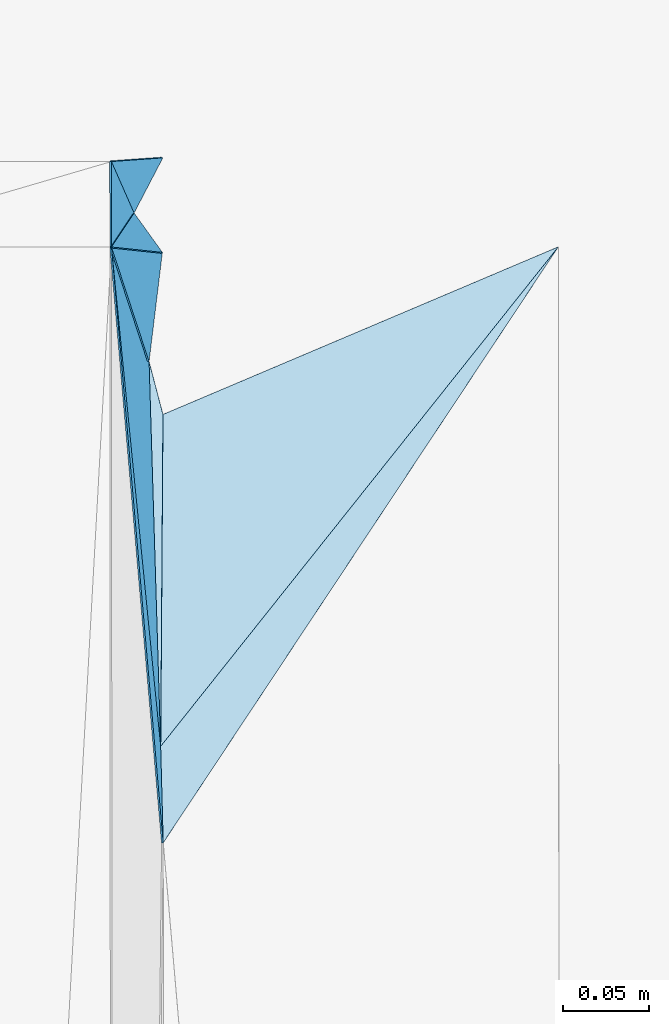
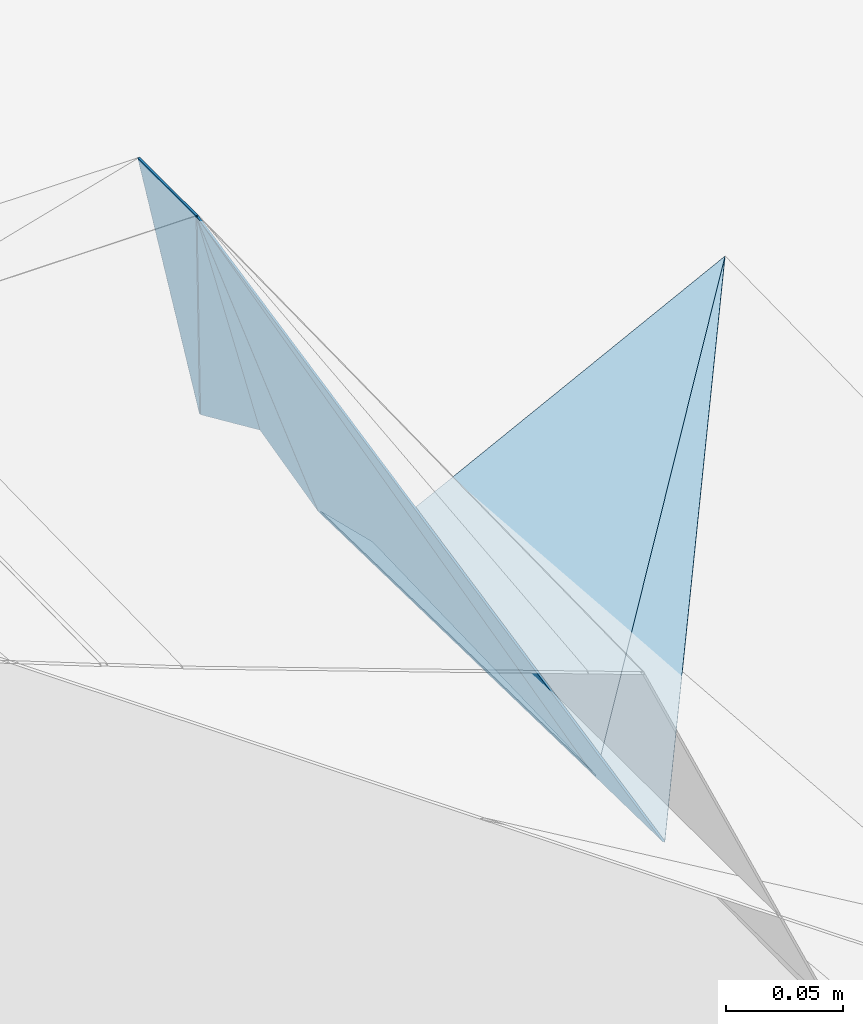
# One storey, part 177 of 275: 9 plates.
"""IFC2X3 building model written with IfcOpenShell, lengths in millimetres."""

from ifc_helpers import new_model, si_unit, frame, origin_with_axes, place, context, subcontext, project, spatial, polyline, outline, extrude, material, type_object, element, save


model = new_model("IFC2X3")

# Units and contexts
model_context = context("Model", 3, precision=1e-05, world=origin_with_axes())
body_context = subcontext(model_context, "Body", "Model", "MODEL_VIEW")
ifc_project = project(units=[si_unit("LENGTHUNIT", "METRE", prefix="MILLI"), si_unit("AREAUNIT", "SQUARE_METRE"), si_unit("VOLUMEUNIT", "CUBIC_METRE"), si_unit("MASSUNIT", "GRAM", prefix="KILO"), si_unit("TIMEUNIT", "SECOND"), si_unit("PLANEANGLEUNIT", "RADIAN"), si_unit("SOLIDANGLEUNIT", "STERADIAN"), si_unit("THERMODYNAMICTEMPERATUREUNIT", "DEGREE_CELSIUS"), si_unit("LUMINOUSINTENSITYUNIT", "LUMEN")], contexts=[model_context])

# Site, building, storey
site_placement = place(None, origin_with_axes())
site = spatial("IfcSite", under=ifc_project, at=site_placement, CompositionType="ELEMENT")
building_placement = place(site_placement, origin_with_axes())
building = spatial("IfcBuilding", under=site, at=building_placement, Name="Undefined", CompositionType="ELEMENT")
storey_placement = place(building_placement, origin_with_axes())
storey = spatial("IfcBuildingStorey", under=building, at=storey_placement, Name="Undefined", CompositionType="ELEMENT", Elevation=0.0)

# Plates
ifc_material = material()
plate_type_1 = type_object("IfcPlateType", PredefinedType="NOTDEFINED")
plate_1_placement = place(storey_placement, frame((-94142.7583722602, 80774.2076939146, 42554.9449686011), z_axis=(-0.867375950582127, 0.452072282208132, -0.208061558224681), x_axis=(-0.105980269993438, 0.240696950969147, 0.964796952817677)))
element("IfcPlate", 1, at=plate_1_placement, inside=storey, type_object=plate_type_1, material=ifc_material, Name="00_PR", context=body_context, shape_type="SweptSolid", body=[
    extrude(outline(polyline([(0.0, 0.0), (124.37850189209, 3.85625753551722e-10), (5.94483232498169, 35.6546897888184), (0.0, 0.0)])), frame((-8.85201319254618e-08, 2.18876761149539e-07, -0.5000001331573), z_axis=(0.0, 0.0, 1.0), x_axis=(1.0, 0.0, 0.0)), (0.0, 0.0, 1.0), 1.0),
])
plate_type_2 = type_object("IfcPlateType", PredefinedType="NOTDEFINED")
plate_2_placement = place(storey_placement, frame((-94155.9850719889, 80754.2292515049, 42674.9944492893), z_axis=(-0.994030688736773, -0.000365980365090597, -0.10910021039333), x_axis=(-0.00036817810698692, 0.999999932222439, -2.76748402294311e-11)))
element("IfcPlate", 2, at=plate_2_placement, inside=storey, type_object=plate_type_2, material=ifc_material, Name="00_PR", context=body_context, shape_type="SweptSolid", body=[
    extrude(outline(polyline([(0.0, 0.0), (49.689754486084, -1.96450855582953e-10), (19.7473754882813, 120.720611572266), (0.0, 0.0)])), frame((-8.85201319254618e-08, 2.18876761149539e-07, -0.5000001331573), z_axis=(0.0, 0.0, 1.0), x_axis=(1.0, 0.0, 0.0)), (0.0, 0.0, 1.0), 1.0),
])
plate_type_3 = type_object("IfcPlateType", PredefinedType="NOTDEFINED")
plate_3_placement = place(storey_placement, frame((-94134.0967544424, 80687.5979098779, 42553.4265810077), z_axis=(-0.962737602424916, 0.123019527590946, -0.240837091637531), x_axis=(-0.15587941593876, 0.475299576709344, 0.865905260445108)))
element("IfcPlate", 3, at=plate_3_placement, inside=storey, type_object=plate_type_3, material=ifc_material, Name="00_PR", context=body_context, shape_type="SweptSolid", body=[
    extrude(outline(polyline([(0.0, 0.0), (140.317886352539, -3.8198777474463e-10), (30.3008766174316, 56.421028137207), (0.0, 0.0)])), frame((-8.85201319254618e-08, 2.18876761149539e-07, -0.5000001331573), z_axis=(0.0, 0.0, 1.0), x_axis=(1.0, 0.0, 0.0)), (0.0, 0.0, 1.0), 1.0),
])
plate_type_4 = type_object("IfcPlateType", PredefinedType="NOTDEFINED")
plate_4_placement = place(storey_placement, frame((-94133.5973282973, 80687.5464707228, 42553.0474272175), z_axis=(0.0361171160985423, 0.0201399563112592, -0.999144602189545), x_axis=(0.253899373232063, -0.967175607462918, -0.0103175869805615)))
element("IfcPlate", 4, at=plate_4_placement, inside=storey, type_object=plate_type_4, material=ifc_material, Name="00_PR", context=body_context, shape_type="SweptSolid", body=[
    extrude(outline(polyline([(0.0, 0.0), (31.7903804779053, -7.27595761418343e-11), (218.229110717773, 50.3532638549805), (0.0, 0.0)])), frame((-8.85201319254618e-08, 2.18876761149539e-07, -0.5000001331573), z_axis=(0.0, 0.0, 1.0), x_axis=(1.0, 0.0, 0.0)), (0.0, 0.0, 1.0), 1.0),
])
plate_type_5 = type_object("IfcPlateType", PredefinedType="NOTDEFINED")
plate_5_placement = place(storey_placement, frame((-94127.3695423557, 80463.7022747809, 42549.1975225795), z_axis=(-0.986275361902605, -0.0265882475288504, -0.162953906357687), x_axis=(-0.0900133561065273, 0.913967783193759, 0.395677251059907)))
element("IfcPlate", 5, at=plate_5_placement, inside=storey, type_object=plate_type_5, material=ifc_material, Name="00_PR", context=body_context, shape_type="SweptSolid", body=[
    extrude(outline(polyline([(0.0, 0.0), (317.860076904297, 1.19689502753317e-09), (206.860382080078, 85.8380966186523), (0.0, 0.0)])), frame((-8.85201319254618e-08, 2.18876761149539e-07, -0.5000001331573), z_axis=(0.0, 0.0, 1.0), x_axis=(1.0, 0.0, 0.0)), (0.0, 0.0, 1.0), 1.0),
])
plate_type_6 = type_object("IfcPlateType", PredefinedType="NOTDEFINED")
plate_6_placement = place(storey_placement, frame((-93895.4723955215, 80754.3370529524, 42562.049356912), z_axis=(0.0319742993126876, 0.0201714169868267, -0.999285123535924), x_axis=(-0.622488952070591, -0.781813950260484, -0.0356994639757451)))
element("IfcPlate", 6, at=plate_6_placement, inside=storey, type_object=plate_type_6, material=ifc_material, Name="00_PR", context=body_context, shape_type="SweptSolid", body=[
    extrude(outline(polyline([(0.0, 0.0), (371.714263916016, -2.21189111471176e-09), (219.796188354492, 119.22981262207), (0.0, 0.0)])), frame((-8.85201319254618e-08, 2.18876761149539e-07, -0.5000001331573), z_axis=(0.0, 0.0, 1.0), x_axis=(1.0, 0.0, 0.0)), (0.0, 0.0, 1.0), 1.0),
])
plate_type_7 = type_object("IfcPlateType", PredefinedType="NOTDEFINED")
plate_7_placement = place(storey_placement, frame((-94125.8741293101, 80407.5557186358, 42548.2087853974), z_axis=(-0.985096067105011, -0.0232362572126845, -0.170428327824295), x_axis=(-0.0812953030755474, 0.936077647705463, 0.342271399862832)))
element("IfcPlate", 7, at=plate_7_placement, inside=storey, type_object=plate_type_7, material=ifc_material, Name="00_PR", context=body_context, shape_type="SweptSolid", body=[
    extrude(outline(polyline([(0.0, 0.0), (370.334777832031, -8.11269273981452e-10), (53.017765045166, 18.5727043151855), (0.0, 0.0)])), frame((-8.85201319254618e-08, 2.18876761149539e-07, -0.5000001331573), z_axis=(0.0, 0.0, 1.0), x_axis=(1.0, 0.0, 0.0)), (0.0, 0.0, 1.0), 1.0),
])
plate_type_8 = type_object("IfcPlateType", PredefinedType="NOTDEFINED")
plate_8_placement = place(storey_placement, frame((-93895.4713084325, 80754.3361864808, 42562.0493763711), z_axis=(0.0341482260169314, 0.0184387566530903, -0.999246671704732), x_axis=(-0.552244551829033, -0.832978611944335, -0.034243057959825)))
element("IfcPlate", 8, at=plate_8_placement, inside=storey, type_object=plate_type_8, material=ifc_material, Name="00_PR", context=body_context, shape_type="SweptSolid", body=[
    extrude(outline(polyline([(0.0, 0.0), (416.288757324219, 2.03726813197136e-10), (370.310272216797, 32.277027130127), (0.0, 0.0)])), frame((-8.85201319254618e-08, 2.18876761149539e-07, -0.5000001331573), z_axis=(0.0, 0.0, 1.0), x_axis=(1.0, 0.0, 0.0)), (0.0, 0.0, 1.0), 1.0),
])
plate_type_9 = type_object("IfcPlateType", PredefinedType="NOTDEFINED")
plate_9_placement = place(storey_placement, frame((-94126.2692234493, 80750.8043622925, 42554.9579733047), z_axis=(-0.798408605549786, -0.573934483284737, -0.182051936218015), x_axis=(-0.239548871925904, 0.0253808050108761, 0.970552498681049)))
element("IfcPlate", 9, at=plate_9_placement, inside=storey, type_object=plate_type_9, material=ifc_material, Name="00_PR", context=body_context, shape_type="SweptSolid", body=[
    extrude(outline(polyline([(0.0, 0.0), (123.640914916992, -1.74622982740402e-10), (4.52267265319824, 27.8256855010986), (0.0, 0.0)])), frame((-8.85201319254618e-08, 2.18876761149539e-07, -0.5000001331573), z_axis=(0.0, 0.0, 1.0), x_axis=(1.0, 0.0, 0.0)), (0.0, 0.0, 1.0), 1.0),
])

save(model, "model.ifc")
